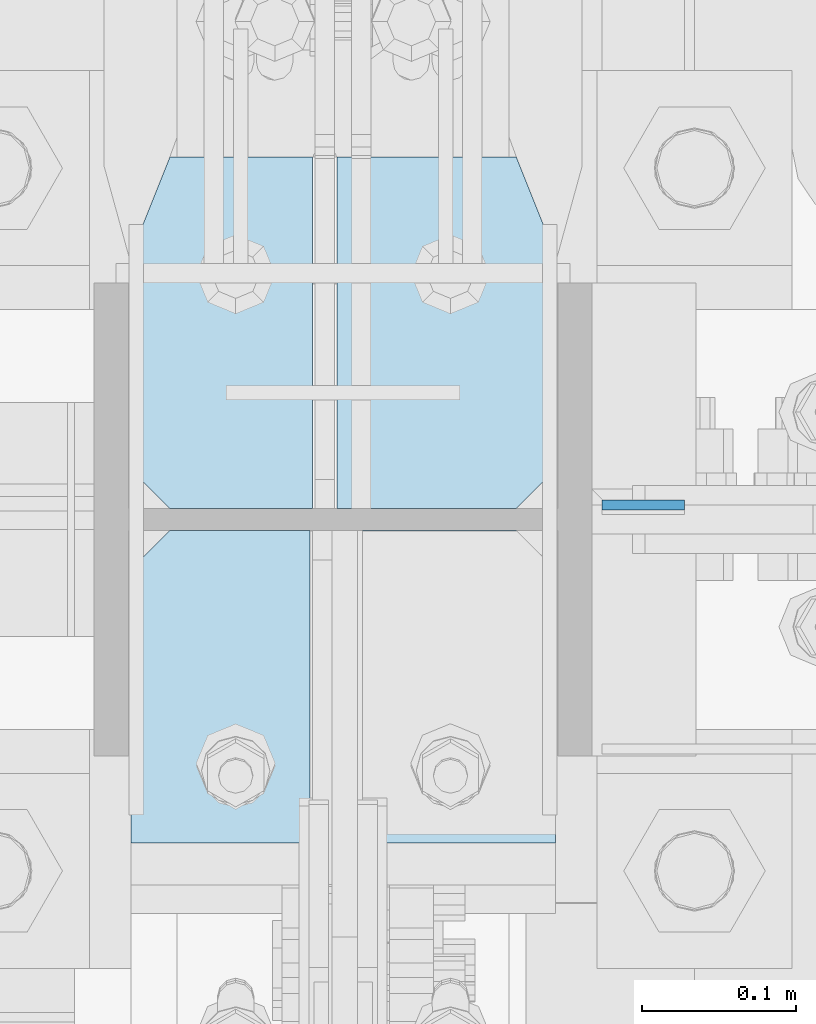
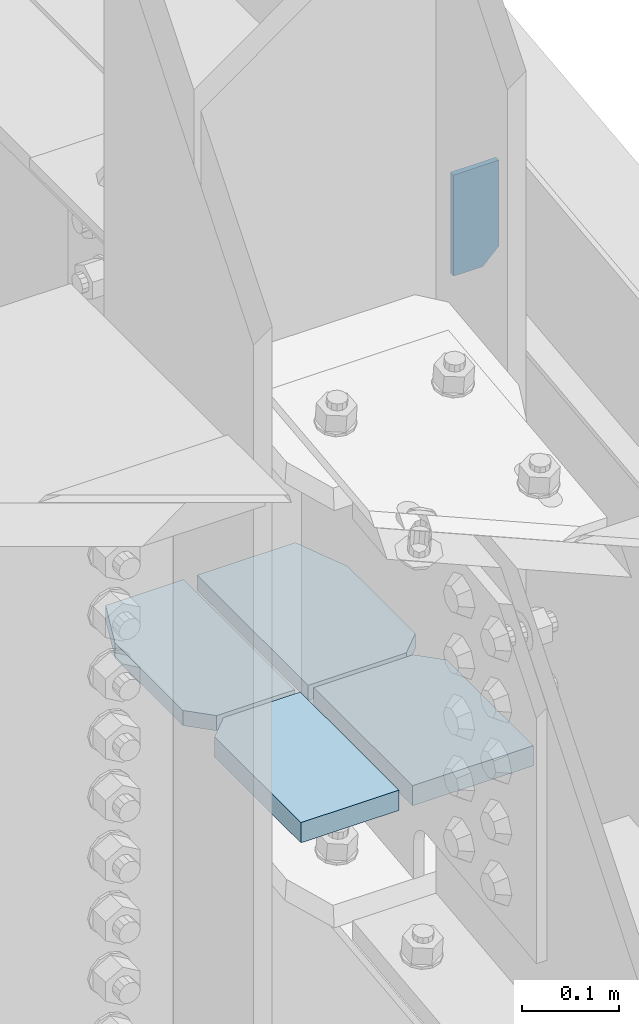
# One storey, part 1088 of 1179: 5 plates, 4 elements without a shape of their own.
"""IFC2X3 building model written with IfcOpenShell, lengths in millimetres."""

from ifc_helpers import new_model, si_unit, frame, origin_with_axes, place, context, subcontext, project, spatial, faceted_brep, material, type_object, element, aggregate, save


model = new_model("IFC2X3")

# Units and contexts
model_context = context("Model", 3, precision=1e-05, world=origin_with_axes())
body_context = subcontext(model_context, "Body", "Model", "MODEL_VIEW")
ifc_project = project(units=[si_unit("LENGTHUNIT", "METRE", prefix="MILLI"), si_unit("AREAUNIT", "SQUARE_METRE"), si_unit("VOLUMEUNIT", "CUBIC_METRE"), si_unit("MASSUNIT", "GRAM", prefix="KILO"), si_unit("TIMEUNIT", "SECOND"), si_unit("PLANEANGLEUNIT", "RADIAN"), si_unit("SOLIDANGLEUNIT", "STERADIAN"), si_unit("THERMODYNAMICTEMPERATUREUNIT", "DEGREE_CELSIUS"), si_unit("LUMINOUSINTENSITYUNIT", "LUMEN")], contexts=[model_context])

# Site, building, storey
site_placement = place(None, origin_with_axes())
site = spatial("IfcSite", under=ifc_project, at=site_placement, CompositionType="ELEMENT")
building_placement = place(site_placement, origin_with_axes())
building = spatial("IfcBuilding", under=site, at=building_placement, Name="Undefined", CompositionType="ELEMENT")
storey_placement = place(building_placement, origin_with_axes())
storey = spatial("IfcBuildingStorey", under=building, at=storey_placement, Name="Undefined", CompositionType="ELEMENT", Elevation=0.0)

# Assembly, plate
assembly_1_placement = place(storey_placement, origin_with_axes())
assembly_1 = element("IfcElementAssembly", 1, at=assembly_1_placement, inside=storey, Name="BEAM", AssemblyPlace="NOTDEFINED", PredefinedType="RIGID_FRAME")
ifc_material_1 = material(Name="STEEL/A36")
plate_type_1 = type_object("IfcPlateType", PredefinedType="NOTDEFINED")
plate_1_placement = place(assembly_1_placement, frame((24530.05, 34401.125, 13125.45), z_axis=(-1.0, 0.0, 0.0), x_axis=(0.0, 0.0, 1.0)))
plate_1 = element("IfcPlate", 2, at=plate_1_placement, type_object=plate_type_1, material=ifc_material_1, Name="PLATE", context=body_context, shape_type="Brep", body=[
    faceted_brep([(3.63797880709171e-12, -3.17500000000109, 19.0500000000029), (3.1137253245106e-05, -3.17500000000291, 53.9754967970766), (3.1137253245106e-05, 3.17500000000291, 53.9754967970766), (-3.63797880709171e-12, 3.17499999999927, 19.0500000000029), (127.000031137255, -3.17500000000291, 53.9754967970766), (127.000031137255, 3.17500000000291, 53.9754967970766), (127.000000000002, -3.17500000000291, 0.0), (127.000000000002, 3.17500000000291, 0.0), (19.0499992370605, -3.17500000000291, 0.0), (19.0499992370605, 3.17500000000291, 0.0)], [[[0, 1, 2, 3]], [[1, 4, 5, 2]], [[4, 6, 7, 5]], [[6, 8, 9, 7]], [[8, 0, 3, 9]], [[5, 7, 9, 3, 2]], [[8, 6, 4, 1, 0]]]),
])
aggregate(assembly_1, [plate_1])

assembly_2_placement = place(storey_placement, origin_with_axes())
assembly_2 = element("IfcElementAssembly", 3, at=assembly_2_placement, inside=storey, Name="PLATE", AssemblyPlace="NOTDEFINED", PredefinedType="RIGID_FRAME")
ifc_material_2 = material(Name="STEEL/A572-GR.50")
plate_type_2 = type_object("IfcPlateType", PredefinedType="NOTDEFINED")
plate_2_placement = place(assembly_2_placement, frame((24169.6875000126, 34181.2562438206, 12665.0749999996), z_axis=(0.0, 1.0, 0.0), x_axis=(1.0, 0.0, 0.0)))
plate_2 = element("IfcPlate", 4, at=plate_2_placement, type_object=plate_type_2, material=ifc_material_2, Name="PLATE", context=body_context, shape_type="Brep", body=[
    faceted_brep([(0.0, -12.7, 0.0), (9.50323374127038e-06, -12.7000000000007, 177.80000656152), (9.50323374127038e-06, 12.7000000000007, 177.80000656152), (0.0, 12.7, 0.0), (25.4000104793704, -12.7000000000007, 203.200004825681), (25.4000104793704, 12.7000000000007, 203.200004825681), (116.681260756643, -12.7000000000007, 203.1999999584), (116.681260756643, 12.7000000000007, 203.1999999584), (116.681249895326, -12.7000000000007, 4.29281499236822e-10), (116.681249895326, 12.7000000000007, 4.29281499236822e-10)], [[[0, 1, 2, 3]], [[1, 4, 5, 2]], [[4, 6, 7, 5]], [[6, 8, 9, 7]], [[8, 0, 3, 9]], [[5, 7, 9, 3, 2]], [[8, 6, 4, 1, 0]]]),
])
aggregate(assembly_2, [plate_2])

assembly_3_placement = place(storey_placement, origin_with_axes())
assembly_3 = element("IfcElementAssembly", 5, at=assembly_3_placement, inside=storey, Name="PLATE", AssemblyPlace="NOTDEFINED", PredefinedType="RIGID_FRAME")
plate_type_3 = type_object("IfcPlateType", PredefinedType="NOTDEFINED")
plate_3_placement = place(assembly_3_placement, frame((24445.9124999742, 34181.2562438207, 12665.0749999996), z_axis=(0.0, 1.0, 0.0), x_axis=(-1.0, 0.0, 0.0)))
plate_3 = element("IfcPlate", 6, at=plate_3_placement, type_object=plate_type_3, material=ifc_material_2, Name="PLATE", context=body_context, shape_type="Brep", body=[
    faceted_brep([(0.0, -12.7, 0.0), (9.50323374127038e-06, -12.7000000000007, 177.80000656152), (9.50323374127038e-06, 12.7000000000007, 177.80000656152), (0.0, 12.7, 0.0), (25.4000104793704, -12.7000000000007, 203.200004825681), (25.4000104793704, 12.7000000000007, 203.200004825681), (143.668758873093, -12.7000000000007, 203.199999957942), (143.668758873093, 12.7000000000007, 203.199999957942), (143.66875006754, -12.7000000000007, -2.91038304567337e-11), (143.66875006754, 12.7000000000007, -2.91038304567337e-11)], [[[0, 1, 2, 3]], [[1, 4, 5, 2]], [[4, 6, 7, 5]], [[6, 8, 9, 7]], [[8, 0, 3, 9]], [[5, 7, 9, 3, 2]], [[8, 6, 4, 1, 0]]]),
])
aggregate(assembly_3, [plate_3])

# Assembly, plates
assembly_4_placement = place(storey_placement, origin_with_axes())
assembly_4 = element("IfcElementAssembly", 7, at=assembly_4_placement, inside=storey, Name="COLUMN", AssemblyPlace="NOTDEFINED", PredefinedType="RIGID_FRAME")
plate_type_4 = type_object("IfcPlateType", PredefinedType="NOTDEFINED")
plate_4_placement = place(assembly_4_placement, frame((24169.6874999651, 34627.34375, 12661.8999999968), z_axis=(0.0, -1.0, 0.0), x_axis=(1.0, 0.0, 0.0)))
plate_4 = element("IfcPlate", 8, at=plate_4_placement, type_object=plate_type_4, material=ifc_material_2, Name="PLATE", context=body_context, shape_type="Brep", body=[
    faceted_brep([(0.0, 9.52500000000146, 63.5), (25.4000000000015, 9.52499999999964, -1.45519152283669e-11), (25.4000000000015, -9.52499999999964, -1.45519152283669e-11), (0.0, -9.52500000000146, 63.5), (1.06856095953844e-05, -9.52499999999964, 203.200000380995), (1.06856095953844e-05, 9.52499999999964, 203.200000380995), (25.400011639842, -9.52499999999964, 228.599998663231), (25.400011639842, 9.52499999999964, 228.599998663231), (118.268761995132, -9.52499999999964, 228.599993777396), (118.268761995132, 9.52499999999964, 228.599993777396), (118.268749973351, -9.52499999999964, -5.0931703299284e-11), (118.268749973351, 9.52499999999964, -5.0931703299284e-11)], [[[0, 1, 2, 3]], [[4, 5, 0, 3]], [[4, 6, 7, 5]], [[6, 8, 9, 7]], [[8, 10, 11, 9]], [[11, 10, 2, 1]], [[5, 7, 9, 11, 1, 0]], [[10, 8, 6, 4, 3, 2]]]),
])
plate_type_5 = type_object("IfcPlateType", PredefinedType="NOTDEFINED")
plate_5_placement = place(assembly_4_placement, frame((24445.9125000105, 34627.34375, 12661.899999997), z_axis=(0.0, -1.0, 0.0), x_axis=(-1.0, 0.0, 0.0)))
plate_5 = element("IfcPlate", 9, at=plate_5_placement, type_object=plate_type_5, material=ifc_material_2, Name="PLATE", context=body_context, shape_type="Brep", body=[
    faceted_brep([(0.0, 9.52500000000146, 63.5), (25.4000000000015, 9.52499999999964, -1.45519152283669e-11), (25.4000000000015, -9.52499999999964, -1.45519152283669e-11), (0.0, -9.52500000000146, 63.5), (1.06856095953844e-05, -9.52499999999964, 203.200000380995), (1.06856095953844e-05, 9.52499999999964, 203.200000380995), (25.400011639842, -9.52499999999964, 228.599998663231), (25.400011639842, 9.52499999999964, 228.599998663231), (142.081259963888, -9.52499999999964, 228.59999377701), (142.081259963888, 9.52499999999964, 228.59999377701), (142.081249948482, -9.52499999999964, -4.29281499236822e-10), (142.081249948482, 9.52499999999964, -4.29281499236822e-10)], [[[0, 1, 2, 3]], [[4, 5, 0, 3]], [[4, 6, 7, 5]], [[6, 8, 9, 7]], [[8, 10, 11, 9]], [[11, 10, 2, 1]], [[5, 7, 9, 11, 1, 0]], [[10, 8, 6, 4, 3, 2]]]),
])
aggregate(assembly_4, [plate_4, plate_5])

save(model, "model.ifc")
